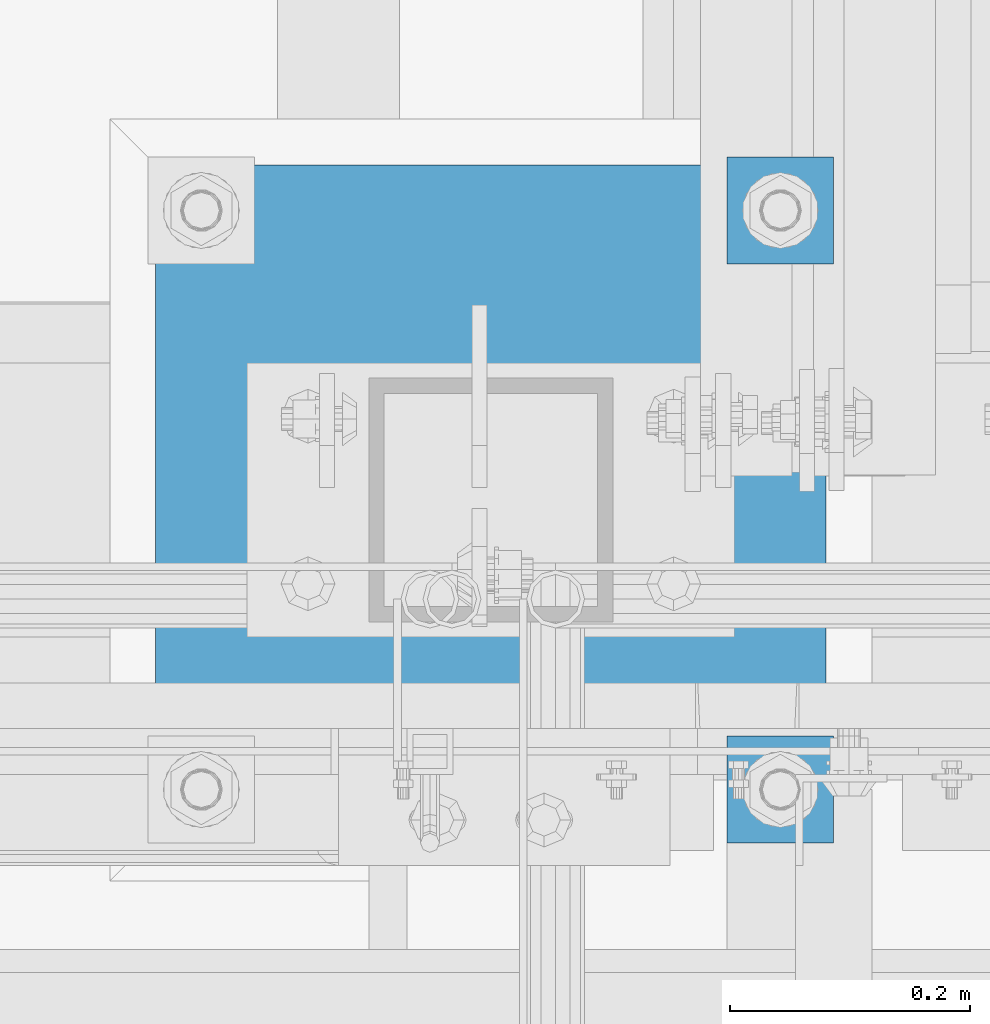
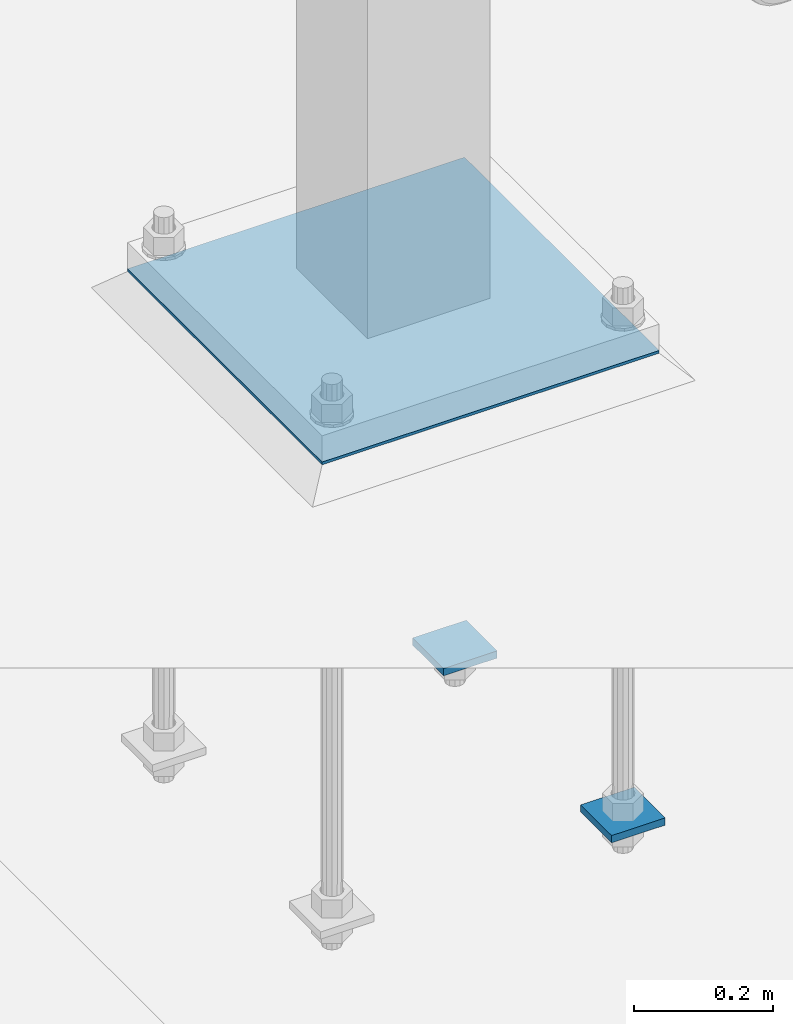
# One storey, part 1175 of 1876: 3 beams, 1 element without a shape of its own.
"""IFC2X3 building model written with IfcOpenShell, lengths in millimetres."""

from ifc_helpers import new_model, si_unit, frame, origin_with_axes, place, context, subcontext, project, spatial, faceted_brep, material, type_object, element, aggregate, save


model = new_model("IFC2X3")

# Units and contexts
model_context = context("Model", 3, precision=1e-05, world=origin_with_axes())
body_context = subcontext(model_context, "Body", "Model", "MODEL_VIEW")
ifc_project = project(units=[si_unit("LENGTHUNIT", "METRE", prefix="MILLI"), si_unit("AREAUNIT", "SQUARE_METRE"), si_unit("VOLUMEUNIT", "CUBIC_METRE"), si_unit("MASSUNIT", "GRAM", prefix="KILO"), si_unit("TIMEUNIT", "SECOND"), si_unit("PLANEANGLEUNIT", "RADIAN"), si_unit("SOLIDANGLEUNIT", "STERADIAN"), si_unit("THERMODYNAMICTEMPERATUREUNIT", "DEGREE_CELSIUS"), si_unit("LUMINOUSINTENSITYUNIT", "LUMEN")], contexts=[model_context])

# Site, building, storey
site_placement = place(None, origin_with_axes())
site = spatial("IfcSite", under=ifc_project, at=site_placement, CompositionType="ELEMENT")
building_placement = place(site_placement, origin_with_axes())
building = spatial("IfcBuilding", under=site, at=building_placement, Name="Undefined", CompositionType="ELEMENT")
storey_placement = place(building_placement, origin_with_axes())
storey = spatial("IfcBuildingStorey", under=building, at=storey_placement, Name="Undefined", CompositionType="ELEMENT", Elevation=0.0)

# Assembly, beams
assembly_placement = place(storey_placement, origin_with_axes())
assembly = element("IfcElementAssembly", 1, at=assembly_placement, inside=storey, Name="TEMPLATE", AssemblyPlace="NOTDEFINED", PredefinedType="RIGID_FRAME")
ifc_material_1 = material(Name="STEEL/A572-GR.50")
beam_type_1 = type_object("IfcBeamType", PredefinedType="NOTDEFINED")
beam_1_placement = place(assembly_placement, frame((2012.95, -4813.3, -781.05), z_axis=(0.0, 1.0, 0.0), x_axis=(-1.0, 0.0, 0.0)))
beam_1 = element("IfcBeam", 2, at=beam_1_placement, type_object=beam_type_1, material=ifc_material_1, Name="PLATE", context=body_context, shape_type="Brep", body=[
    faceted_brep([(0.0, 6.35000000000002, -44.4499999999998), (0.0, 6.35000000000002, 44.4499999999998), (88.9000000000001, 6.35000000000002, 44.4499999999998), (88.9000000000001, 6.35000000000002, -44.4499999999998), (0.0, -6.35000000000002, 44.4499999999998), (88.9000000000001, -6.35000000000002, 44.4499999999998), (0.0, -6.35000000000002, -44.4499999999998), (88.9000000000001, -6.35000000000002, -44.4499999999998)], [[[0, 1, 2, 3]], [[1, 4, 5, 2]], [[4, 6, 7, 5]], [[6, 0, 3, 7]], [[5, 7, 3, 2]], [[6, 4, 1, 0]]]),
])
beam_2_placement = place(assembly_placement, frame((2012.95, -4330.7, -781.05), z_axis=(0.0, 1.0, 0.0), x_axis=(-1.0, 0.0, 0.0)))
beam_2 = element("IfcBeam", 3, at=beam_2_placement, type_object=beam_type_1, material=ifc_material_1, Name="PLATE", context=body_context, shape_type="Brep", body=[
    faceted_brep([(0.0, 6.35000000000002, -44.4499999999998), (0.0, 6.35000000000002, 44.4499999999998), (88.9000000000001, 6.35000000000002, 44.4499999999998), (88.9000000000001, 6.35000000000002, -44.4499999999998), (0.0, -6.35000000000002, 44.4499999999998), (88.9000000000001, -6.35000000000002, 44.4499999999998), (0.0, -6.35000000000002, -44.4499999999998), (88.9000000000001, -6.35000000000002, -44.4499999999998)], [[[0, 1, 2, 3]], [[1, 4, 5, 2]], [[4, 6, 7, 5]], [[6, 0, 3, 7]], [[5, 7, 3, 2]], [[6, 4, 1, 0]]]),
])
ifc_material_2 = material(Name="STEEL/A36")
beam_type_2 = type_object("IfcBeamType", PredefinedType="NOTDEFINED")
beam_3_placement = place(assembly_placement, frame((2006.6, -4572.0, 40.4815), z_axis=(0.0, -1.0, 0.0), x_axis=(-1.0, 0.0, 0.0)))
beam_3 = element("IfcBeam", 4, at=beam_3_placement, type_object=beam_type_2, material=ifc_material_2, Name="TEMPLATE", context=body_context, shape_type="Brep", body=[
    faceted_brep([(0.0, 2.3815, -279.4), (0.0, 2.3815, 279.4), (558.8, 2.3815, 279.4), (558.8, 2.3815, -279.4), (0.0, -2.3815, 279.4), (558.8, -2.3815, 279.4), (0.0, -2.3815, -279.4), (558.8, -2.3815, -279.4)], [[[0, 1, 2, 3]], [[1, 4, 5, 2]], [[4, 6, 7, 5]], [[6, 0, 3, 7]], [[5, 7, 3, 2]], [[6, 4, 1, 0]]]),
])
aggregate(assembly, [beam_1, beam_2, beam_3])

save(model, "model.ifc")
